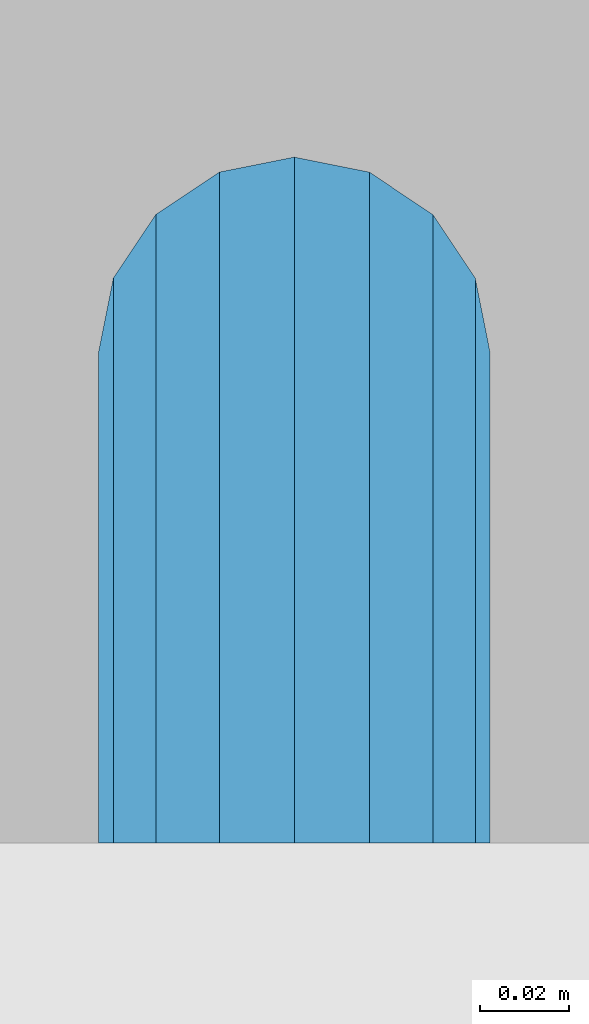
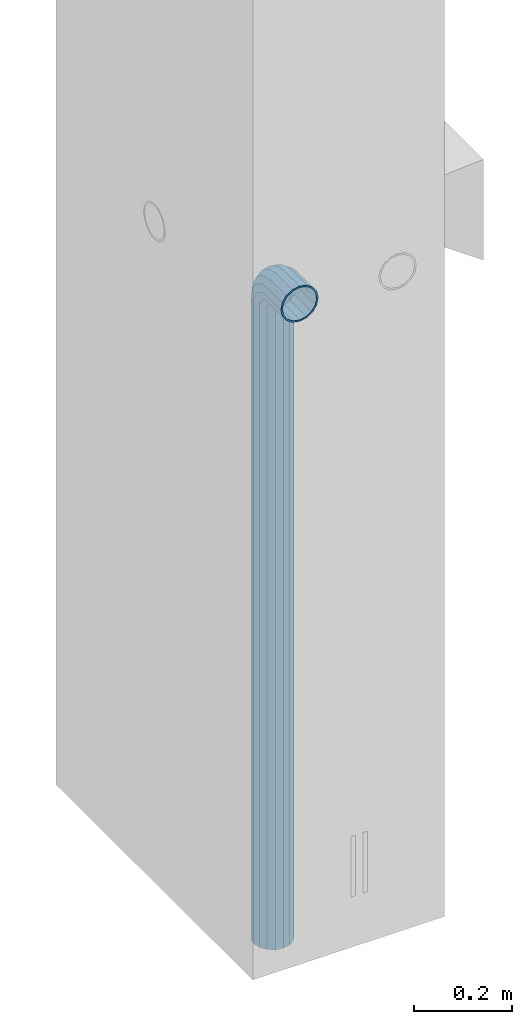
# One storey, part 4 of 41: 1 beam, 2 elements without a shape of their own.
"""IFC2X3 building model written with IfcOpenShell, lengths in millimetres."""

from ifc_helpers import new_model, si_unit, frame, origin_with_axes, place, context, subcontext, project, spatial, faceted_brep, material, type_object, element, aggregate, save


model = new_model("IFC2X3")

# Units and contexts
model_context = context("Model", 3, precision=1e-05, world=origin_with_axes())
body_context = subcontext(model_context, "Body", "Model", "MODEL_VIEW")
ifc_project = project(units=[si_unit("LENGTHUNIT", "METRE", prefix="MILLI"), si_unit("AREAUNIT", "SQUARE_METRE"), si_unit("VOLUMEUNIT", "CUBIC_METRE"), si_unit("MASSUNIT", "GRAM", prefix="KILO"), si_unit("TIMEUNIT", "SECOND"), si_unit("PLANEANGLEUNIT", "RADIAN"), si_unit("SOLIDANGLEUNIT", "STERADIAN"), si_unit("THERMODYNAMICTEMPERATUREUNIT", "DEGREE_CELSIUS"), si_unit("LUMINOUSINTENSITYUNIT", "LUMEN")], contexts=[model_context])

# Site, building, storey
site_placement = place(None, frame((-177556.685383467, -198018.589999756, 1290.0), z_axis=(0.0, 0.0, 1.0), x_axis=(0.788225611989142, -0.615386370180835, 0.0)))
site = spatial("IfcSite", under=ifc_project, at=site_placement, CompositionType="ELEMENT")
building_placement = place(site_placement, origin_with_axes())
building = spatial("IfcBuilding", under=site, at=building_placement, Name="Undefined", CompositionType="ELEMENT")
storey_placement = place(building_placement, origin_with_axes())
storey = spatial("IfcBuildingStorey", under=building, at=storey_placement, Name="Undefined", CompositionType="ELEMENT", Elevation=0.0)

# Assemblies, beam
assembly_1_placement = place(storey_placement, origin_with_axes())
assembly_1 = element("IfcElementAssembly", 1, at=assembly_1_placement, inside=storey, AssemblyPlace="NOTDEFINED", PredefinedType="REINFORCEMENT_UNIT")
assembly_2_placement = place(assembly_1_placement, origin_with_axes())
assembly_2 = element("IfcElementAssembly", 2, at=assembly_2_placement, AssemblyPlace="NOTDEFINED", PredefinedType="RIGID_FRAME")
aggregate(assembly_1, [assembly_2])
ifc_material = material(Name="STEEL/NEG_BETON")
beam_type = type_object("IfcBeamType", PredefinedType="NOTDEFINED")
beam_placement = place(assembly_2_placement, frame((18184.6017728418, 265049.933547208, -1290.0), z_axis=(0.615386370178831, -0.788225611990706, 0.0), x_axis=(0.0, 0.0, 1.0)))
beam = element("IfcBeam", 3, at=beam_placement, type_object=beam_type, material=ifc_material, context=body_context, shape_type="Brep", body=[
    faceted_brep([(0.0, -43.999999753345, 2.88331648334861e-07), (0.0, -40.6506991838105, -16.8380707357428), (1590.0, -40.6506991838105, -16.8380707357428), (1589.99999999999, -43.999999753345, 2.88331648334861e-07), (0.0, -31.1126981254783, -31.1126980838017), (1590.0, -31.1126981254783, -31.1126980838017), (0.0, -16.8380707773322, -40.6506991419883), (1590.0, -16.8380707773322, -40.6506991419883), (0.0, 2.46742274612188e-07, -43.9999997114064), (1590.0, 2.46742274612188e-07, -43.9999997114064), (0.0, 16.8380712707876, -40.6506991418137), (1590.0, 16.8380712707876, -40.6506991418137), (0.0, 31.1126986189047, -31.1126980834524), (1590.0, 31.1126986189047, -31.1126980834524), (0.0, 40.6506996771204, -16.8380707352771), (1590.0, 40.6506996771204, -16.8380707352771), (0.0, 44.0000002465677, 2.88768205791712e-07), (1590.0, 44.0000002465677, 2.88768205791712e-07), (0.0, 40.6506996770622, 16.8380713128427), (1590.0, 40.6506996770622, 16.8380713128427), (0.0, 31.1126986187301, 31.1126986609306), (1590.0, 31.1126986187301, 31.1126986609306), (0.0, 16.8380712705839, 40.6506997191464), (1590.0, 16.8380712705839, 40.6506997191464), (0.0, 2.46509443968534e-07, 44.0000002885354), (1590.0, 2.46509443968534e-07, 44.0000002885354), (0.0, -16.8380707775359, 40.6506997189426), (1590.0, -16.8380707775359, 40.6506997189426), (0.0, -31.1126981256821, 31.1126986605814), (1590.0, -31.1126981256821, 31.1126986605814), (0.0, -40.6506991838978, 16.838071312377), (1590.0, -40.6506991838978, 16.838071312377), (4.47878846898675e-07, -40.0000000634464, 0.0), (4.47878846898675e-07, -36.9551813638827, 15.3073372946019), (1590.0, -36.9551810538396, 15.3073375829845), (1589.99999999999, -39.999999753345, 2.88360752165318e-07), (4.47937054559588e-07, -28.2842713108694, 28.284271247463), (1590.0, -28.2842710008845, 28.2842715359002), (4.4800981413573e-07, -15.3073373580119, 36.9551813004509), (1590.0, -15.3073370480561, 36.9551815889135), (4.48068021796644e-07, -6.34463503956795e-08, 40.0), (1590.0, 2.46538547798991e-07, 40.0000002885645), (4.48140781372786e-07, 15.3073372311774, 36.9551813004509), (1590.0, 15.3073375411332, 36.9551815890882), (4.48213540948927e-07, 28.2842711840058, 28.284271247463), (1590.0, 28.2842714939907, 28.2842715361621), (4.48271748609841e-07, 36.95518123699, 15.3073372946019), (1590.0, 36.9551815469749, 15.3073375833046), (4.48286300525069e-07, 39.9999999365536, 0.0), (1590.0, 40.0000002465677, 2.88768205791712e-07), (4.48271748609841e-07, 36.95518123699, -15.3073372946019), (1590.0, 36.9551815470913, -15.3073370058555), (4.48213540948927e-07, 28.2842711840058, -28.284271247463), (1590.0, 28.2842714941071, -28.2842709587712), (4.48140781372786e-07, 15.3073372311774, -36.9551813004509), (1590.0, 15.3073375413369, -36.9551810117846), (4.48068021796644e-07, -6.34463503956795e-08, -40.0), (1590.0, 2.46742274612188e-07, -39.9999997114064), (4.4800981413573e-07, -15.3073373580119, -36.9551813004509), (1590.0, -15.3073370479106, -36.9551810119592), (4.47937054559588e-07, -28.2842713108694, -28.284271247463), (1590.0, -28.284271000739, -28.2842709590332), (4.47878846898675e-07, -36.9551813638827, -15.3073372946019), (1590.0, -36.9551810537523, -15.3073370062048), (1602.94095225512, -43.9999997540726, 1.70370897403336), (1598.5829387913, -40.6506991846254, 17.9680366410757), (1594.88839337186, -31.1126981263515, 31.7562678573595), (1592.41977704577, -16.8380707782635, 40.9692694107944), (1591.55291427061, 2.45810952037573e-07, 44.2044453310082), (1592.41977704577, 16.8380712698563, 40.969269410969), (1594.88839337186, 31.1126986180025, 31.7562678576505), (1598.5829387913, 40.6506996763346, 17.9680366415123), (1602.94095225512, 44.0000002458692, 1.70370897452813), (1607.29896571893, 40.6506996763928, -14.5606186925434), (1610.99351113838, 31.112698618148, -28.3488499088271), (1613.46212746447, 16.83807127006, -37.561851462262), (1614.32899023963, 2.4601467885077e-07, -40.7970273824176), (1613.46212746447, -16.8380707780307, -37.5618514623784), (1610.99351113838, -31.1126981262059, -28.348849909089), (1607.29896571893, -40.650699184509, -14.5606186929217), (1613.29371405922, 2.45985575020313e-07, -36.9333240772539), (1612.50565699089, 15.3073375405802, -33.9922550588963), (1610.26146033081, 28.2842714934086, -25.6167991012626), (1606.90278267677, 36.9551815463637, -13.0820434500929), (1602.94095225512, 40.0000002458692, 1.70370897449902), (1598.97912183347, 36.9551815463055, 16.4894613990327), (1595.62044417943, 28.2842714932631, 29.024217050086), (1593.37624751934, 15.3073375403765, 37.3996730076324), (1592.58819045102, 2.45781848207116e-07, 40.3407420258154), (1593.37624751934, -15.3073370488128, 37.3996730074577), (1595.62044417943, -28.2842710016412, 29.0242170498241), (1598.97912183347, -36.9551810545672, 16.4894613986544), (1602.94095225512, -39.9999997540726, 1.70370897406247), (1606.90278267677, -36.955181054509, -13.0820434504712), (1610.26146033081, -28.2842710014374, -25.6167991015245), (1612.50565699089, -15.307337048609, -33.9922550590418), (1630.55634918609, 31.112698618148, -20.2456570709182), (1635.32534971524, 16.8380712700309, -28.5058082887845), (1623.41903551202, 40.6506996764219, -7.883467157837), (1614.99999999999, 44.0000002458692, 6.69873009974253), (1606.58096448796, 40.6506996763346, 21.2809273572639), (1599.44365081389, 31.1126986180025, 33.6431172702578), (1594.67465028474, 16.8380712698563, 41.9032684879785), (1592.99999999999, 2.45752744376659e-07, 44.8038478659873), (1594.67465028474, -16.8380707782635, 41.9032684878039), (1599.44365081389, -31.1126981263515, 33.6431172699668), (1606.58096448796, -40.6506991846254, 21.2809273568855), (1614.99999999999, -43.9999997540726, 6.69873009927687), (1623.41903551202, -40.6506991845672, -7.88346715827356), (1630.55634918609, -31.1126981262059, -20.2456570712384), (1635.32534971524, -16.8380707780598, -28.5058082889591), (1636.99999999999, 2.45956471189857e-07, -31.4063876669679), (1633.47759065022, -15.3073370486381, -25.3053957082157), (1634.99999999999, 2.45985575020313e-07, -27.9422860518389), (1629.14213562372, -28.2842710014665, -17.7961673284299), (1622.65366864729, -36.9551810545381, -6.55781286209822), (1614.99999999999, -39.9999997541017, 6.69873009933508), (1607.34633135269, -36.9551810545381, 19.9552730607684), (1600.85786437626, -28.2842710016121, 31.1936275271582), (1596.52240934976, -15.3073370487837, 38.7028559070604), (1594.99999999999, 2.45810952037573e-07, 41.3397462508583), (1596.52240934976, 15.3073375404056, 38.702855907206), (1600.85786437626, 28.2842714932631, 31.1936275275075), (1607.34633135269, 36.9551815462473, 19.9552730610885), (1614.99999999999, 40.0000002458692, 6.69873009974253), (1622.65366864729, 36.9551815463346, -6.55781286169076), (1629.14213562372, 28.2842714933795, -17.7961673281679), (1633.47759065022, 15.3073375405511, -25.305395708041), (1647.35533905931, 31.1126986181189, -7.35533877040143), (1654.09972428659, 16.8380712700018, -14.0997239977587), (1637.26165326252, 40.6506996763928, 2.73834702643217), (1625.35533905931, 44.0000002458401, 14.6446612296568), (1613.4490248561, 40.6506996763346, 26.5509754328523), (1603.35533905931, 31.1126986179734, 36.6446612295404), (1596.61095383203, 16.8380712698563, 43.3890464567812), (1594.24264068711, 2.45810952037573e-07, 45.7573596016155), (1596.61095383203, -16.8380707782344, 43.3890464565775), (1603.35533905931, -31.1126981263806, 36.6446612292202), (1613.4490248561, -40.6506991846254, 26.5509754324157), (1625.35533905931, -43.9999997541017, 14.644661229162), (1637.26165326252, -40.6506991845672, 2.73834702599561), (1647.35533905931, -31.1126981262641, -7.35533877075068), (1654.09972428659, -16.838070778118, -14.0997239979333), (1656.46803743151, 2.45956471189857e-07, -16.4680371427676), (1651.48659835683, -15.3073370486381, -11.4865980681498), (1653.63961030677, 2.45956471189857e-07, -13.6396100180573), (1645.35533905931, -28.2842710015248, -5.35533877072157), (1636.17926106223, -36.955181054509, 3.82073922632844), (1625.35533905931, -39.9999997541017, 14.6446612291911), (1614.53141705639, -36.9551810545672, 25.4685832321702), (1605.35533905931, -28.2842710016121, 34.6446612292784), (1599.22407976179, -15.3073370487837, 40.775920526823), (1597.07106781185, 2.45781848207116e-07, 42.9289324768179), (1599.22407976179, 15.3073375403765, 40.7759205269977), (1605.35533905931, 28.2842714932631, 34.6446612295404), (1614.53141705639, 36.9551815462764, 25.4685832324903), (1625.35533905931, 40.0000002458401, 14.6446612296277), (1636.17926106223, 36.9551815463346, 3.82073922670679), (1645.35533905931, 28.2842714933795, -5.35533877045964), (1651.48659835683, 15.307337540522, -11.4865980680042), (1660.24565735981, 31.1126986180607, 9.44365110280341), (1668.50580857761, 16.8380712699436, 4.67465057360823), (1647.88346744676, 40.6506996763055, 16.5809647768911), (1633.3012701892, 44.000000245811, 25.0000002889719), (1618.71907293164, 40.6506996763055, 33.4190358009655), (1606.35688301859, 31.1126986179734, 40.5563494749367), (1598.09673180079, 16.8380712698563, 45.3253500040737), (1595.19615242269, 2.45781848207116e-07, 47.00000028871), (1598.09673180079, -16.8380707782635, 45.32535000387), (1606.35688301859, -31.1126981263806, 40.5563494746748), (1618.71907293164, -40.6506991846545, 33.419035800558), (1633.3012701892, -43.9999997541308, 25.0000002884772), (1647.88346744676, -40.6506991845963, 16.5809647764836), (1660.24565735981, -31.1126981262933, 9.44365110251238), (1668.50580857761, -16.8380707781762, 4.67465057340451), (1671.40638795571, 2.459273673594e-07, 3.00000028876821), (1665.30539599684, -15.3073370486964, 6.52240963847726), (1667.94228634057, 2.45898263528943e-07, 5.00000028876821), (1657.79616761703, -28.2842710015539, 10.8578646648966), (1646.55781315062, -36.9551810545672, 17.3463316412526), (1633.3012701892, -39.9999997541308, 25.0000002885063), (1620.04472722778, -36.9551810546254, 32.6536689358181), (1608.80637276137, -28.2842710016412, 39.1421359122905), (1601.29714438156, -15.3073370488128, 43.4775909388554), (1598.66025403783, 2.45781848207116e-07, 45.0000002886809), (1601.29714438156, 15.3073375403765, 43.4775909390009), (1608.80637276137, 28.2842714932631, 39.1421359125816), (1620.04472722778, 36.9551815462473, 32.6536689362256), (1633.3012701892, 40.0000002458401, 25.0000002889428), (1646.55781315062, 36.9551815463055, 17.346331641631), (1657.79616761703, 28.2842714933213, 10.8578646651586), (1665.30539599684, 15.3073375404638, 6.52240963859367), (1668.34885019768, 31.1126986180316, 29.0064891505172), (1677.56185175105, 16.8380712698563, 26.5378728243522), (1654.56061898146, 40.6506996763055, 32.7010345700255), (1638.29629131443, 44.0000002457818, 37.0590480338433), (1622.0319636474, 40.6506996763055, 41.4170614976319), (1608.24373243118, 31.1126986179734, 45.1116069169948), (1599.03073087781, 16.8380712698563, 47.5802232430142), (1595.79555495772, 2.45781848207116e-07, 48.4470860181027), (1599.03073087781, -16.8380707782635, 47.5802232428396), (1608.24373243118, -31.1126981263806, 45.1116069167037), (1622.0319636474, -40.6506991846836, 41.4170614971954), (1638.29629131443, -43.9999997541599, 37.0590480333485), (1654.56061898146, -40.6506991846254, 32.701034569589), (1668.34885019768, -31.1126981263515, 29.006489150197), (1677.56185175105, -16.8380707782053, 26.5378728241776), (1680.79702767114, 2.4584005586803e-07, 25.6710100491182), (1673.99225534772, -15.3073370487546, 27.4943432977598), (1676.93332436598, 2.4584005586803e-07, 26.7062862295134), (1665.61679939011, -28.284271001583, 29.7385399577906), (1653.082043739, -36.9551810545963, 33.0972176117939), (1638.29629131443, -39.9999997541599, 37.0590480334067), (1623.51053888986, -36.9551810546545, 41.0208784550487), (1610.97578323875, -28.2842710016412, 44.3795561091392), (1602.60032728114, -15.3073370487837, 46.6237527692865), (1599.65925826287, 2.45810952037573e-07, 47.4118098377076), (1602.60032728114, 15.3073375403474, 46.623752769432), (1610.97578323875, 28.284271493234, 44.3795561094012), (1623.51053888986, 36.9551815462182, 41.0208784554561), (1638.29629131443, 40.0000002457818, 37.0590480338142), (1653.082043739, 36.9551815462473, 33.097217612114), (1665.61679939011, 28.2842714932631, 29.7385399580817), (1673.99225534772, 15.3073375404347, 27.4943432979344), (1671.11269837217, -31.1126981263806, 50.0000002885645), (1656.83807102403, -40.6506991847127, 50.0000002885063), (1680.65069943045, -16.8380707782635, 50.0000002886227), (1683.99999999996, 2.45781848207116e-07, 50.0000002887391), (1680.65069943045, 16.8380712698563, 50.0000002887973), (1671.11269837217, 31.1126986179734, 50.0000002888555), (1656.83807102403, 40.6506996762473, 50.0000002889428), (1639.99999999997, 44.0000002457236, 50.0000002889137), (1623.16192897591, 40.6506996762473, 50.0000002889428), (1608.88730162777, 31.1126986179734, 50.0000002888555), (1599.34930056949, 16.8380712698563, 50.0000002887973), (1595.99999999998, 2.45781848207116e-07, 50.0000002887391), (1599.34930056949, -16.8380707782635, 50.0000002886227), (1608.88730162777, -31.1126981263806, 50.0000002885645), (1623.16192897591, -40.6506991846836, 50.0000002885063), (1640.0, -43.999999754189, 50.0000002885063), (1676.95518130041, -15.3073370488128, 50.0000002886227), (1679.99999999996, 2.45781848207116e-07, 50.0000002887391), (1668.28427124742, -28.2842710016703, 50.0000002885645), (1655.30733729457, -36.9551810546545, 50.0000002885354), (1640.0, -39.999999754189, 50.0000002885063), (1624.69266270537, -36.9551810546545, 50.0000002885354), (1611.71572875252, -28.2842710016703, 50.0000002885645), (1603.04481869953, -15.3073370488128, 50.0000002886227), (1599.99999999998, 2.45781848207116e-07, 50.0000002887391), (1603.04481869953, 15.3073375403765, 50.0000002887973), (1611.71572875252, 28.284271493234, 50.0000002888555), (1624.69266270537, 36.9551815461891, 50.0000002888846), (1639.99999999997, 40.0000002457236, 50.0000002889137), (1655.30733729457, 36.9551815461891, 50.0000002889137), (1668.28427124742, 28.284271493234, 50.0000002888555), (1676.95518130041, 15.3073375403765, 50.0000002887973), (1656.83807102406, -40.6506991848582, 110.000000288477), (1640.0, -43.9999997543346, 110.000000288477), (1671.11269837221, -31.1126981265552, 110.000000288535), (1680.6506994305, -16.838070778409, 110.000000288594), (1684.0, 2.45607225224376e-07, 110.00000028871), (1680.6506994305, 16.8380712696817, 110.000000288768), (1671.11269837221, 31.1126986177987, 110.000000288826), (1656.83807102406, 40.6506996761018, 110.000000288914), (1640.0, 44.0000002455781, 110.000000288914), (1623.16192897594, 40.6506996761018, 110.000000288914), (1608.88730162779, 31.1126986177987, 110.000000288826), (1599.3493005695, 16.8380712696817, 110.000000288768), (1596.0, 2.45607225224376e-07, 110.00000028871), (1599.3493005695, -16.838070778409, 110.000000288594), (1608.88730162779, -31.1126981265552, 110.000000288535), (1623.16192897594, -40.6506991848582, 110.000000288477), (1624.6926627054, -36.9551810548001, 110.000000288535), (1640.0, -39.9999997543346, 110.000000288477), (1611.71572875254, -28.2842710018158, 110.000000288535), (1603.04481869955, -15.3073370489583, 110.000000288594), (1600.0, 2.45607225224376e-07, 110.00000028871), (1603.04481869955, 15.3073375402309, 110.000000288768), (1611.71572875254, 28.2842714930885, 110.000000288856), (1624.6926627054, 36.9551815460436, 110.000000288856), (1640.0, 40.0000002455781, 110.000000288885), (1655.3073372946, 36.9551815460436, 110.000000288856), (1668.28427124746, 28.2842714930885, 110.000000288856), (1676.95518130045, 15.3073375402309, 110.000000288768), (1680.0, 2.45607225224376e-07, 110.00000028871), (1676.95518130045, -15.3073370489583, 110.000000288594), (1668.28427124746, -28.2842710018158, 110.000000288535), (1655.3073372946, -36.9551810548001, 110.000000288535)], [[[0, 1, 2, 3]], [[1, 4, 5, 2]], [[4, 6, 7, 5]], [[6, 8, 9, 7]], [[8, 10, 11, 9]], [[10, 12, 13, 11]], [[12, 14, 15, 13]], [[14, 16, 17, 15]], [[16, 18, 19, 17]], [[18, 20, 21, 19]], [[20, 22, 23, 21]], [[22, 24, 25, 23]], [[24, 26, 27, 25]], [[26, 28, 29, 27]], [[28, 30, 31, 29]], [[30, 0, 3, 31]], [[32, 33, 34, 35]], [[33, 36, 37, 34]], [[36, 38, 39, 37]], [[38, 40, 41, 39]], [[40, 42, 43, 41]], [[42, 44, 45, 43]], [[44, 46, 47, 45]], [[46, 48, 49, 47]], [[48, 50, 51, 49]], [[50, 52, 53, 51]], [[52, 54, 55, 53]], [[54, 56, 57, 55]], [[56, 58, 59, 57]], [[58, 60, 61, 59]], [[60, 62, 63, 61]], [[62, 32, 35, 63]], [[30, 28, 26, 24, 22, 20, 18, 16, 14, 12, 10, 8, 6, 4, 1, 0], [62, 60, 58, 56, 54, 52, 50, 48, 46, 44, 42, 40, 38, 36, 33, 32]], [[31, 3, 64, 65]], [[29, 31, 65, 66]], [[27, 29, 66, 67]], [[25, 27, 67, 68]], [[23, 25, 68, 69]], [[21, 23, 69, 70]], [[19, 21, 70, 71]], [[17, 19, 71, 72]], [[15, 17, 72, 73]], [[13, 15, 73, 74]], [[11, 13, 74, 75]], [[9, 11, 75, 76]], [[7, 9, 76, 77]], [[5, 7, 77, 78]], [[2, 5, 78, 79]], [[3, 2, 79, 64]], [[55, 57, 80, 81]], [[53, 55, 81, 82]], [[51, 53, 82, 83]], [[49, 51, 83, 84]], [[47, 49, 84, 85]], [[45, 47, 85, 86]], [[43, 45, 86, 87]], [[41, 43, 87, 88]], [[39, 41, 88, 89]], [[37, 39, 89, 90]], [[34, 37, 90, 91]], [[35, 34, 91, 92]], [[63, 35, 92, 93]], [[61, 63, 93, 94]], [[59, 61, 94, 95]], [[57, 59, 95, 80]], [[74, 96, 97, 75]], [[73, 98, 96, 74]], [[72, 99, 98, 73]], [[71, 100, 99, 72]], [[70, 101, 100, 71]], [[69, 102, 101, 70]], [[68, 103, 102, 69]], [[67, 104, 103, 68]], [[66, 105, 104, 67]], [[65, 106, 105, 66]], [[64, 107, 106, 65]], [[79, 108, 107, 64]], [[78, 109, 108, 79]], [[77, 110, 109, 78]], [[76, 111, 110, 77]], [[75, 97, 111, 76]], [[95, 112, 113, 80]], [[94, 114, 112, 95]], [[93, 115, 114, 94]], [[92, 116, 115, 93]], [[91, 117, 116, 92]], [[90, 118, 117, 91]], [[89, 119, 118, 90]], [[88, 120, 119, 89]], [[87, 121, 120, 88]], [[86, 122, 121, 87]], [[85, 123, 122, 86]], [[84, 124, 123, 85]], [[83, 125, 124, 84]], [[82, 126, 125, 83]], [[81, 127, 126, 82]], [[80, 113, 127, 81]], [[96, 128, 129, 97]], [[98, 130, 128, 96]], [[99, 131, 130, 98]], [[100, 132, 131, 99]], [[101, 133, 132, 100]], [[102, 134, 133, 101]], [[103, 135, 134, 102]], [[104, 136, 135, 103]], [[105, 137, 136, 104]], [[106, 138, 137, 105]], [[107, 139, 138, 106]], [[108, 140, 139, 107]], [[109, 141, 140, 108]], [[110, 142, 141, 109]], [[111, 143, 142, 110]], [[97, 129, 143, 111]], [[112, 144, 145, 113]], [[114, 146, 144, 112]], [[115, 147, 146, 114]], [[116, 148, 147, 115]], [[117, 149, 148, 116]], [[118, 150, 149, 117]], [[119, 151, 150, 118]], [[120, 152, 151, 119]], [[121, 153, 152, 120]], [[122, 154, 153, 121]], [[123, 155, 154, 122]], [[124, 156, 155, 123]], [[125, 157, 156, 124]], [[126, 158, 157, 125]], [[127, 159, 158, 126]], [[113, 145, 159, 127]], [[128, 160, 161, 129]], [[130, 162, 160, 128]], [[131, 163, 162, 130]], [[132, 164, 163, 131]], [[133, 165, 164, 132]], [[134, 166, 165, 133]], [[135, 167, 166, 134]], [[136, 168, 167, 135]], [[137, 169, 168, 136]], [[138, 170, 169, 137]], [[139, 171, 170, 138]], [[140, 172, 171, 139]], [[141, 173, 172, 140]], [[142, 174, 173, 141]], [[143, 175, 174, 142]], [[129, 161, 175, 143]], [[144, 176, 177, 145]], [[146, 178, 176, 144]], [[147, 179, 178, 146]], [[148, 180, 179, 147]], [[149, 181, 180, 148]], [[150, 182, 181, 149]], [[151, 183, 182, 150]], [[152, 184, 183, 151]], [[153, 185, 184, 152]], [[154, 186, 185, 153]], [[155, 187, 186, 154]], [[156, 188, 187, 155]], [[157, 189, 188, 156]], [[158, 190, 189, 157]], [[159, 191, 190, 158]], [[145, 177, 191, 159]], [[160, 192, 193, 161]], [[162, 194, 192, 160]], [[163, 195, 194, 162]], [[164, 196, 195, 163]], [[165, 197, 196, 164]], [[166, 198, 197, 165]], [[167, 199, 198, 166]], [[168, 200, 199, 167]], [[169, 201, 200, 168]], [[170, 202, 201, 169]], [[171, 203, 202, 170]], [[172, 204, 203, 171]], [[173, 205, 204, 172]], [[174, 206, 205, 173]], [[175, 207, 206, 174]], [[161, 193, 207, 175]], [[176, 208, 209, 177]], [[178, 210, 208, 176]], [[179, 211, 210, 178]], [[180, 212, 211, 179]], [[181, 213, 212, 180]], [[182, 214, 213, 181]], [[183, 215, 214, 182]], [[184, 216, 215, 183]], [[185, 217, 216, 184]], [[186, 218, 217, 185]], [[187, 219, 218, 186]], [[188, 220, 219, 187]], [[189, 221, 220, 188]], [[190, 222, 221, 189]], [[191, 223, 222, 190]], [[177, 209, 223, 191]], [[205, 224, 225, 204]], [[206, 226, 224, 205]], [[207, 227, 226, 206]], [[193, 228, 227, 207]], [[192, 229, 228, 193]], [[194, 230, 229, 192]], [[195, 231, 230, 194]], [[196, 232, 231, 195]], [[197, 233, 232, 196]], [[198, 234, 233, 197]], [[199, 235, 234, 198]], [[200, 236, 235, 199]], [[201, 237, 236, 200]], [[202, 238, 237, 201]], [[203, 239, 238, 202]], [[204, 225, 239, 203]], [[208, 240, 241, 209]], [[210, 242, 240, 208]], [[211, 243, 242, 210]], [[212, 244, 243, 211]], [[213, 245, 244, 212]], [[214, 246, 245, 213]], [[215, 247, 246, 214]], [[216, 248, 247, 215]], [[217, 249, 248, 216]], [[218, 250, 249, 217]], [[219, 251, 250, 218]], [[220, 252, 251, 219]], [[221, 253, 252, 220]], [[222, 254, 253, 221]], [[223, 255, 254, 222]], [[209, 241, 255, 223]], [[239, 225, 256, 257]], [[225, 224, 258, 256]], [[224, 226, 259, 258]], [[226, 227, 260, 259]], [[227, 228, 261, 260]], [[228, 229, 262, 261]], [[229, 230, 263, 262]], [[230, 231, 264, 263]], [[231, 232, 265, 264]], [[232, 233, 266, 265]], [[233, 234, 267, 266]], [[234, 235, 268, 267]], [[235, 236, 269, 268]], [[236, 237, 270, 269]], [[237, 238, 271, 270]], [[238, 239, 257, 271]], [[244, 245, 272, 273]], [[245, 246, 274, 272]], [[246, 247, 275, 274]], [[247, 248, 276, 275]], [[248, 249, 277, 276]], [[249, 250, 278, 277]], [[250, 251, 279, 278]], [[251, 252, 280, 279]], [[252, 253, 281, 280]], [[253, 254, 282, 281]], [[254, 255, 283, 282]], [[255, 241, 284, 283]], [[241, 240, 285, 284]], [[240, 242, 286, 285]], [[242, 243, 287, 286]], [[243, 244, 273, 287]], [[258, 259, 260, 261, 262, 263, 264, 265, 266, 267, 268, 269, 270, 271, 257, 256], [274, 275, 276, 277, 278, 279, 280, 281, 282, 283, 284, 285, 286, 287, 273, 272]]]),
])
aggregate(assembly_2, [beam])

save(model, "model.ifc")
